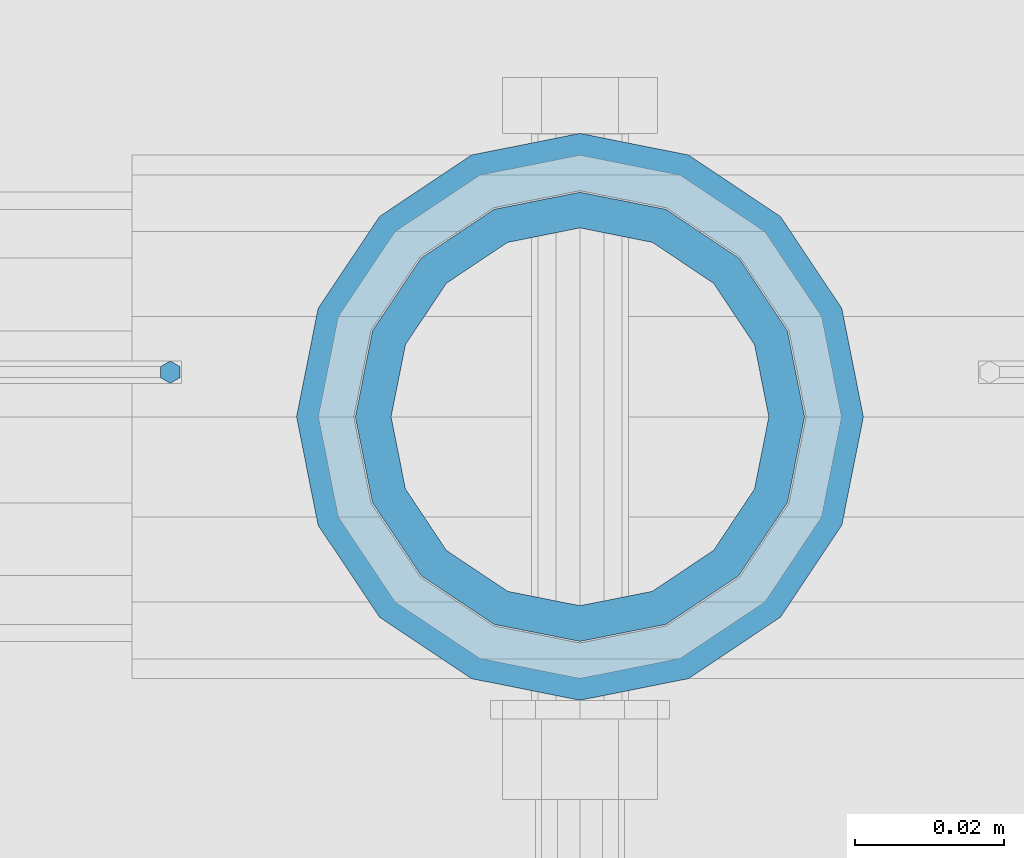
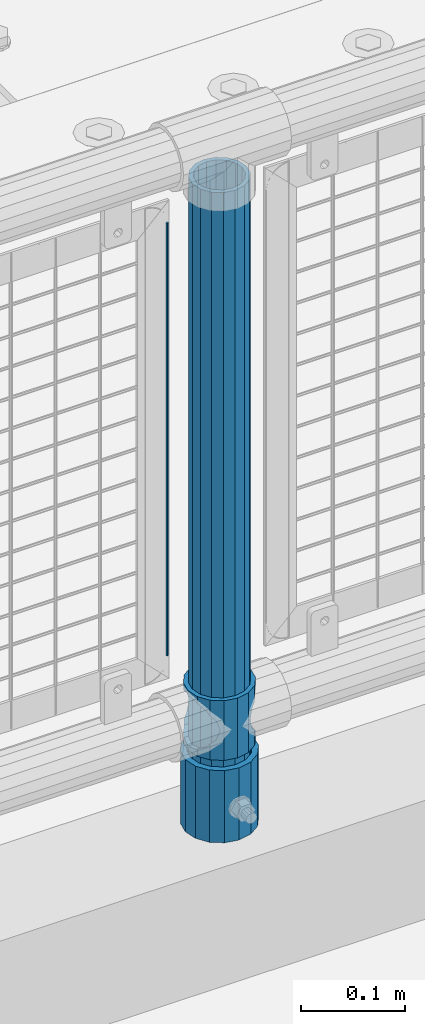
# One storey, part 78 of 257: 4 columns.
"""IFC2X3 building model written with IfcOpenShell, lengths in millimetres."""

from ifc_helpers import new_model, si_unit, frame, origin_with_axes, place, context, subcontext, project, spatial, faceted_brep, material, type_object, element, save


model = new_model("IFC2X3")

# Units and contexts
model_context = context("Model", 3, precision=1e-05, world=origin_with_axes())
body_context = subcontext(model_context, "Body", "Model", "MODEL_VIEW")
ifc_project = project(units=[si_unit("LENGTHUNIT", "METRE", prefix="MILLI"), si_unit("AREAUNIT", "SQUARE_METRE"), si_unit("VOLUMEUNIT", "CUBIC_METRE"), si_unit("MASSUNIT", "GRAM", prefix="KILO"), si_unit("TIMEUNIT", "SECOND"), si_unit("PLANEANGLEUNIT", "RADIAN"), si_unit("SOLIDANGLEUNIT", "STERADIAN"), si_unit("THERMODYNAMICTEMPERATUREUNIT", "DEGREE_CELSIUS"), si_unit("LUMINOUSINTENSITYUNIT", "LUMEN")], contexts=[model_context])

# Site, building, storey
site_placement = place(None, origin_with_axes())
site = spatial("IfcSite", under=ifc_project, at=site_placement, CompositionType="ELEMENT")
building_placement = place(site_placement, origin_with_axes())
building = spatial("IfcBuilding", under=site, at=building_placement, Name="Standard", CompositionType="ELEMENT")
storey_placement = place(building_placement, origin_with_axes())
storey = spatial("IfcBuildingStorey", under=building, at=storey_placement, Name="Undefined", CompositionType="ELEMENT", Elevation=0.0)

# Columns
ifc_material_1 = material()
column_type_1 = type_object("IfcColumnType", PredefinedType="NOTDEFINED")
column_1_placement = place(storey_placement, frame((49471.0, 10664.5, 168.02), z_axis=(0.0, 1.0, 0.0), x_axis=(0.0, 0.0, 1.0)))
element("IfcColumn", 1, at=column_1_placement, inside=storey, type_object=column_type_1, material=ifc_material_1, context=body_context, shape_type="Brep", body=[
    faceted_brep([(0.0, -31.75, 0.0), (0.0, -29.3331751572332, 12.1501989775916), (85.0, -29.3331751572332, 12.1501989775916), (85.0, -31.75, 0.0), (0.0, -22.4506403026753, 22.4506403026735), (85.0, -22.4506403026753, 22.4506403026735), (0.0, -12.1501989775934, 29.3331751572332), (85.0, -12.1501989775934, 29.3331751572332), (0.0, 0.0, 31.75), (85.0, 0.0, 31.75), (0.0, 12.1501989775934, 29.3331751572332), (85.0, 12.1501989775934, 29.3331751572332), (0.0, 22.4506403026753, 22.4506403026735), (85.0, 22.4506403026753, 22.4506403026735), (0.0, 29.3331751572332, 12.1501989775916), (85.0, 29.3331751572332, 12.1501989775916), (0.0, 31.75, 0.0), (85.0, 31.75, 0.0), (0.0, 29.3331751572332, -12.1501989775916), (85.0, 29.3331751572332, -12.1501989775916), (0.0, 22.4506403026753, -22.4506403026735), (85.0, 22.4506403026753, -22.4506403026735), (0.0, 12.1501989775934, -29.3331751572332), (85.0, 12.1501989775934, -29.3331751572332), (0.0, 0.0, -31.75), (85.0, 0.0, -31.75), (0.0, -12.1501989775934, -29.3331751572332), (85.0, -12.1501989775934, -29.3331751572332), (0.0, -22.4506403026753, -22.4506403026735), (85.0, -22.4506403026753, -22.4506403026735), (0.0, -29.3331751572332, -12.1501989775916), (85.0, -29.3331751572332, -12.1501989775916), (0.0, -38.0500000000029, 0.0), (0.0, -35.1536162120537, -14.561104601491), (85.0, -35.1536162120537, -14.561104601491), (85.0, -38.0500000000029, 0.0), (0.0, -26.9054130241493, -26.9054130241475), (85.0, -26.9054130241493, -26.9054130241475), (0.0, -14.5611046014892, -35.1536162120537), (85.0, -14.5611046014892, -35.1536162120537), (0.0, 0.0, -38.0499999999993), (85.0, 0.0, -38.0499999999993), (0.0, 14.5611046014892, -35.1536162120537), (85.0, 14.5611046014892, -35.1536162120537), (0.0, 26.9054130241493, -26.9054130241475), (85.0, 26.9054130241493, -26.9054130241475), (0.0, 35.1536162120537, -14.561104601491), (85.0, 35.1536162120537, -14.561104601491), (0.0, 38.0500000000029, 0.0), (85.0, 38.0500000000029, 0.0), (0.0, 35.1536162120537, 14.561104601491), (85.0, 35.1536162120537, 14.561104601491), (0.0, 26.9054130241493, 26.9054130241475), (85.0, 26.9054130241493, 26.9054130241475), (0.0, 14.5611046014892, 35.1536162120537), (85.0, 14.5611046014892, 35.1536162120537), (0.0, 0.0, 38.0499999999993), (85.0, 0.0, 38.0499999999993), (0.0, -14.5611046014892, 35.1536162120537), (85.0, -14.5611046014892, 35.1536162120537), (0.0, -26.9054130241493, 26.9054130241475), (85.0, -26.9054130241493, 26.9054130241475), (0.0, -35.1536162120537, 14.561104601491), (85.0, -35.1536162120537, 14.561104601491)], [[[0, 1, 2, 3]], [[1, 4, 5, 2]], [[4, 6, 7, 5]], [[6, 8, 9, 7]], [[8, 10, 11, 9]], [[10, 12, 13, 11]], [[12, 14, 15, 13]], [[14, 16, 17, 15]], [[16, 18, 19, 17]], [[18, 20, 21, 19]], [[20, 22, 23, 21]], [[22, 24, 25, 23]], [[24, 26, 27, 25]], [[26, 28, 29, 27]], [[28, 30, 31, 29]], [[30, 0, 3, 31]], [[32, 33, 34, 35]], [[33, 36, 37, 34]], [[36, 38, 39, 37]], [[38, 40, 41, 39]], [[40, 42, 43, 41]], [[42, 44, 45, 43]], [[44, 46, 47, 45]], [[46, 48, 49, 47]], [[48, 50, 51, 49]], [[50, 52, 53, 51]], [[52, 54, 55, 53]], [[54, 56, 57, 55]], [[56, 58, 59, 57]], [[58, 60, 61, 59]], [[60, 62, 63, 61]], [[62, 32, 35, 63]], [[37, 39, 41, 43, 45, 47, 49, 51, 53, 55, 57, 59, 61, 63, 35, 34], [5, 7, 9, 11, 13, 15, 17, 19, 21, 23, 25, 27, 29, 31, 3, 2]], [[62, 60, 58, 56, 54, 52, 50, 48, 46, 44, 42, 40, 38, 36, 33, 32], [30, 28, 26, 24, 22, 20, 18, 16, 14, 12, 10, 8, 6, 4, 1, 0]]]),
])
ifc_material_2 = material(Name="Misc_Undefined")
column_type_2 = type_object("IfcColumnType", PredefinedType="NOTDEFINED")
column_2_placement = place(storey_placement, frame((49471.0, 10664.5, 263.02), z_axis=(-1.0, 0.0, 0.0), x_axis=(0.0, 0.0, 1.0)))
element("IfcColumn", 2, at=column_2_placement, inside=storey, type_object=column_type_2, material=ifc_material_2, context=body_context, shape_type="Brep", body=[
    faceted_brep([(63.1897438117172, 11.6144421722802, -32.8397438117245), (63.1897438117172, 11.6144421722802, -28.0397438117143), (56.6106908090114, 21.4606908090118, -21.4606908090136), (56.6106908090114, 21.4606908090118, -27.1226768591077), (61.9623795176756, 13.4513226476338, -32.4743655677739), (46.7644421722801, 28.0397438117179, -11.6144421722784), (46.7644421722801, 28.0397438117179, -20.0882031229921), (51.5310424080039, 24.8548033587067, -24.8548033587067), (35.1500000000015, 30.35, 0.0), (35.1499999999996, 30.3500000000004, -16.6306603983758), (23.5355578277192, 28.0397438117179, -11.6144421722784), (23.5355578277192, 28.0397438117179, -20.0882031229921), (18.7689575919954, 24.8548033587067, -24.8548033587067), (13.6893091909879, 21.4606908090118, -21.4606908090136), (13.6893091909879, 21.4606908090118, -27.1226768591077), (8.3376204823237, 13.4513226476338, -32.4743655677739), (7.11025618828211, 11.6144421722802, -28.0397438117143), (7.11025618828211, 11.6144421722802, -32.8397438117245), (4.79999999999961, 0.0, -30.3499999999985), (4.79999999999961, 0.0, -35.1500000000015), (7.11025618828205, -11.6144421722802, -28.0397438117143), (7.11025618828205, -11.6144421722802, -32.8397438117245), (13.6893091909879, -21.4606908090118, -21.4606908090136), (13.6893091909879, -21.4606908090118, -27.1226768591077), (8.33762048232484, -13.4513226476338, -32.4743655677739), (23.5355578277191, -28.0397438117179, -11.6144421722784), (23.5355578277191, -28.0397438117179, -20.0882031229849), (18.7689575919987, -24.8548033587067, -24.8548033587067), (35.1500000000015, -30.35, 0.0), (35.1499999999996, -30.3500000000004, -16.6306603983685), (46.7644421722801, -28.0397438117179, -11.6144421722784), (46.7644421722801, -28.0397438117179, -20.0882031229849), (51.5310424080038, -24.8548033587067, -24.8548033587067), (56.6106908090114, -21.4606908090118, -21.4606908090136), (56.6106908090114, -21.4606908090118, -27.1226768591077), (61.9623795176756, -13.4513226476338, -32.4743655677739), (63.1897438117172, -11.6144421722802, -28.0397438117143), (63.1897438117172, -11.6144421722802, -32.8397438117245), (65.4999999999997, 0.0, -30.3499999999985), (65.4999999999997, 0.0, -35.1500000000015), (0.0, -28.0397438117179, -11.6144421722784), (0.0, -30.3500000000004, 0.0), (0.0, -21.4606908090118, -21.4606908090136), (0.0, -11.6144421722802, -28.0397438117143), (0.0, 0.0, -30.3499999999985), (0.0, 11.6144421722802, -28.0397438117143), (0.0, 21.4606908090118, -21.4606908090136), (0.0, 28.0397438117179, -11.6144421722784), (0.0, 30.3500000000004, 0.0), (0.0, 28.0397438117179, 11.6144421722784), (23.5355578277192, 28.0397438117179, 11.6144421722784), (0.0, 21.4606908090118, 21.4606908090136), (13.6893091909879, 21.4606908090118, 21.4606908090136), (0.0, 11.6144421722802, 28.0397438117143), (7.11025618828211, 11.6144421722802, 28.0397438117143), (0.0, 0.0, 30.3499999999985), (4.79999999999961, 0.0, 30.3499999999985), (0.0, -11.6144421722802, 28.0397438117143), (7.11025618828205, -11.6144421722802, 28.0397438117143), (0.0, -21.4606908090118, 21.4606908090136), (13.6893091909879, -21.4606908090118, 21.4606908090136), (0.0, -28.0397438117179, 11.6144421722784), (23.5355578277191, -28.0397438117179, 11.6144421722784), (0.0, -32.4743655677721, 13.4513226476338), (0.0, -35.1499999999996, 0.0), (70.2999999999993, -35.1499999999996, 0.0), (70.2999999999993, -32.4743655677721, 13.4513226476338), (0.0, 13.4513226476338, -32.4743655677739), (0.0, 24.8548033587067, -24.8548033587067), (0.0, 0.0, -35.1499999999996), (0.0, -13.4513226476338, -32.4743655677739), (0.0, -24.8548033587067, -24.8548033587067), (0.0, -24.8548033587067, 24.8548033587067), (0.0, -13.4513226476338, 32.4743655677739), (0.0, 0.0, 35.1499999999996), (0.0, 13.4513226476338, 32.4743655677739), (0.0, 24.8548033587067, 24.8548033587067), (0.0, 32.4743655677721, 13.4513226476338), (0.0, 35.1499999999996, 0.0), (0.0, 32.4743655677721, -13.4513226476338), (0.0, -32.4743655677721, -13.4513226476338), (70.2999999999993, 32.4743655677721, 13.4513226476338), (70.2999999999993, 35.1499999999996, 0.0), (70.2999999999993, 32.4743655677721, -13.4513226476338), (70.2999999999993, 24.8548033587067, -24.8548033587067), (70.2999999999993, 13.4513226476338, -32.4743655677739), (70.2999999999993, 0.0, -35.1500000000015), (70.2999999999993, -13.4513226476338, -32.4743655677739), (70.2999999999993, -24.8548033587067, -24.8548033587067), (70.2999999999993, -32.4743655677721, -13.4513226476338), (70.2999999999993, 28.0397438117179, 11.6144421722784), (70.2999999999993, 21.4606908090118, 21.4606908090136), (56.6106908090114, 21.4606908090118, 21.4606908090136), (46.7644421722801, 28.0397438117179, 11.6144421722784), (70.2999999999993, 11.6144421722802, 28.0397438117143), (63.1897438117172, 11.6144421722802, 28.0397438117143), (70.2999999999993, 0.0, 30.3499999999985), (65.4999999999997, 0.0, 30.3499999999985), (70.2999999999993, -11.6144421722802, 28.0397438117143), (63.1897438117172, -11.6144421722802, 28.0397438117143), (70.2999999999993, -21.4606908090118, 21.4606908090136), (56.6106908090114, -21.4606908090118, 21.4606908090136), (70.2999999999993, -28.0397438117179, 11.6144421722784), (46.7644421722801, -28.0397438117179, 11.6144421722784), (70.2999999999993, -11.6144421722802, -28.0397438117143), (70.2999999999993, 0.0, -30.3499999999985), (70.2999999999993, -21.4606908090118, -21.4606908090136), (70.2999999999993, -28.0397438117179, -11.6144421722784), (70.2999999999993, -30.3500000000004, 0.0), (70.2999999999993, 24.8548033587067, 24.8548033587067), (70.2999999999993, 13.4513226476338, 32.4743655677739), (70.2999999999993, 0.0, 35.1500000000015), (70.2999999999993, -13.4513226476338, 32.4743655677739), (70.2999999999993, -24.8548033587067, 24.8548033587067), (70.2999999999993, 30.3500000000004, 0.0), (70.2999999999993, 28.0397438117179, -11.6144421722784), (70.2999999999993, 21.4606908090118, -21.4606908090136), (70.2999999999993, 11.6144421722802, -28.0397438117143), (61.9623795176756, 13.4513226476338, 32.4743655677739), (51.5310424080039, 24.8548033587067, 24.8548033587067), (56.6106908090114, 21.4606908090118, 27.1226768591077), (65.4999999999997, 0.0, 35.1500000000015), (63.1897438117172, 11.6144421722802, 32.8397438117172), (63.1897438117172, -11.6144421722802, 32.8397438117172), (61.9623795176756, -13.4513226476338, 32.4743655677739), (56.6106908090114, -21.4606908090118, 27.1226768591077), (51.5310424080071, -24.8548033587067, 24.8548033587067), (18.7689575919987, -24.8548033587067, 24.8548033587067), (46.7644421722801, -28.0397438117179, 20.0882031229703), (35.1499999999996, -30.3500000000004, 16.6306603983539), (23.5355578277191, -28.0397438117179, 20.0882031229703), (8.3376204823237, -13.4513226476338, 32.4743655677739), (13.6893091909879, -21.4606908090118, 27.1226768591077), (4.79999999999961, 0.0, 35.1500000000015), (7.11025618828205, -11.6144421722802, 32.8397438117172), (7.11025618828211, 11.6144421722802, 32.8397438117172), (8.3376204823237, 13.4513226476338, 32.4743655677739), (13.6893091909879, 21.4606908090118, 27.1226768591077), (18.7689575919954, 24.8548033587067, 24.8548033587067), (23.5355578277192, 28.0397438117179, 20.0882031229849), (35.1499999999996, 30.3500000000004, 16.6306603983685), (46.7644421722801, 28.0397438117179, 20.0882031229849)], [[[0, 1, 2, 3, 4]], [[3, 2, 5, 6, 7]], [[6, 5, 8, 9]], [[9, 8, 10, 11]], [[12, 11, 10, 13, 14]], [[15, 14, 13, 16, 17]], [[17, 16, 18, 19]], [[19, 18, 20, 21]], [[21, 20, 22, 23, 24]], [[23, 22, 25, 26, 27]], [[26, 25, 28, 29]], [[29, 28, 30, 31]], [[32, 31, 30, 33, 34]], [[35, 34, 33, 36, 37]], [[37, 36, 38, 39]], [[39, 38, 1, 0]], [[40, 41, 28, 25]], [[42, 40, 25, 22]], [[43, 42, 22, 20]], [[44, 43, 20, 18]], [[45, 44, 18, 16]], [[46, 45, 16, 13]], [[47, 46, 13, 10]], [[48, 47, 10, 8]], [[49, 48, 8, 50]], [[51, 49, 50, 52]], [[53, 51, 52, 54]], [[55, 53, 54, 56]], [[57, 55, 56, 58]], [[59, 57, 58, 60]], [[61, 59, 60, 62]], [[41, 61, 62, 28]], [[63, 64, 65, 66]], [[67, 68, 12, 14, 15]], [[69, 67, 15, 17, 19]], [[24, 70, 69, 19, 21]], [[27, 71, 70, 24, 23]], [[63, 72, 73, 74, 75, 76, 77, 78, 79, 68, 67, 69, 70, 71, 80, 64], [40, 42, 43, 44, 45, 46, 47, 48, 49, 51, 53, 55, 57, 59, 61, 41]], [[78, 77, 81, 82]], [[79, 78, 82, 83]], [[9, 11, 12, 68, 79, 83, 84, 7, 6]], [[7, 84, 85, 4, 3]], [[4, 85, 86, 39, 0]], [[87, 88, 32, 34, 35]], [[86, 87, 35, 37, 39]], [[88, 89, 80, 71, 27, 26, 29, 31, 32]], [[64, 80, 89, 65]], [[90, 91, 92, 93]], [[91, 94, 95, 92]], [[94, 96, 97, 95]], [[96, 98, 99, 97]], [[98, 100, 101, 99]], [[100, 102, 103, 101]], [[104, 105, 38, 36]], [[106, 104, 36, 33]], [[107, 106, 33, 30]], [[108, 107, 30, 28]], [[102, 108, 28, 103]], [[88, 87, 86, 85, 84, 83, 82, 81, 109, 110, 111, 112, 113, 66, 65, 89], [100, 98, 96, 94, 91, 90, 114, 115, 116, 117, 105, 104, 106, 107, 108, 102]], [[118, 110, 109, 119, 120]], [[121, 111, 110, 118, 122]], [[112, 111, 121, 123, 124]], [[113, 112, 124, 125, 126]], [[127, 72, 63, 66, 113, 126, 128, 129, 130]], [[131, 73, 72, 127, 132]], [[133, 74, 73, 131, 134]], [[75, 74, 133, 135, 136]], [[76, 75, 136, 137, 138]], [[119, 109, 81, 77, 76, 138, 139, 140, 141]], [[92, 120, 119, 141, 93]], [[95, 122, 118, 120, 92]], [[97, 121, 122, 95]], [[99, 123, 121, 97]], [[101, 125, 124, 123, 99]], [[103, 128, 126, 125, 101]], [[28, 129, 128, 103]], [[62, 130, 129, 28]], [[60, 132, 127, 130, 62]], [[58, 134, 131, 132, 60]], [[56, 133, 134, 58]], [[54, 135, 133, 56]], [[52, 137, 136, 135, 54]], [[50, 139, 138, 137, 52]], [[8, 140, 139, 50]], [[93, 141, 140, 8]], [[114, 90, 93, 8]], [[115, 114, 8, 5]], [[116, 115, 5, 2]], [[117, 116, 2, 1]], [[105, 117, 1, 38]]]),
])
column_type_3 = type_object("IfcColumnType", PredefinedType="NOTDEFINED")
column_3_placement = place(storey_placement, frame((49471.0, 10664.5, 168.02), z_axis=(-1.0, 0.0, 0.0), x_axis=(0.0, 0.0, 1.0)))
element("IfcColumn", 3, at=column_3_placement, inside=storey, type_object=column_type_3, material=ifc_material_1, context=body_context, shape_type="Brep", body=[
    faceted_brep([(0.0, -25.3500000000004, 0.0), (0.0, -23.4203461491616, 9.70102501045767), (760.0, -23.4203461491616, 9.70102501045767), (760.0, -25.3500000000004, 0.0), (0.0, -17.9251569030785, 17.9251569030821), (760.0, -17.9251569030785, 17.9251569030821), (0.0, -9.70102501045585, 23.4203461491634), (760.0, -9.70102501045585, 23.4203461491634), (0.0, 0.0, 25.3499999999985), (760.0, 0.0, 25.3499999999985), (0.0, 9.70102501045585, 23.4203461491634), (760.0, 9.70102501045585, 23.4203461491634), (0.0, 17.9251569030785, 17.9251569030821), (760.0, 17.9251569030785, 17.9251569030821), (0.0, 23.4203461491616, 9.70102501045767), (760.0, 23.4203461491616, 9.70102501045767), (0.0, 25.3500000000004, 0.0), (760.0, 25.3500000000004, 0.0), (0.0, 23.4203461491616, -9.70102501045767), (760.0, 23.4203461491616, -9.70102501045767), (0.0, 17.9251569030785, -17.9251569030821), (760.0, 17.9251569030785, -17.9251569030821), (0.0, 9.70102501045585, -23.4203461491634), (760.0, 9.70102501045585, -23.4203461491634), (0.0, 0.0, -25.3499999999985), (760.0, 0.0, -25.3499999999985), (0.0, -9.70102501045585, -23.4203461491634), (760.0, -9.70102501045585, -23.4203461491634), (0.0, -17.9251569030785, -17.9251569030821), (760.0, -17.9251569030785, -17.9251569030821), (0.0, -23.4203461491616, -9.70102501045767), (760.0, -23.4203461491616, -9.70102501045767), (0.0, -30.1499999999996, 0.0), (0.0, -27.8549679052157, -11.5379054858058), (760.0, -27.8549679052157, -11.5379054858058), (760.0, -30.1499999999996, 0.0), (0.0, -21.3192694527752, -21.3192694527752), (760.0, -21.3192694527752, -21.3192694527752), (0.0, -11.5379054858076, -27.8549679052157), (760.0, -11.5379054858076, -27.8549679052157), (0.0, 0.0, -30.1500000000015), (760.0, 0.0, -30.1500000000015), (0.0, 11.5379054858076, -27.8549679052157), (760.0, 11.5379054858076, -27.8549679052157), (0.0, 21.3192694527752, -21.3192694527752), (760.0, 21.3192694527752, -21.3192694527752), (0.0, 27.8549679052157, -11.5379054858058), (760.0, 27.8549679052157, -11.5379054858058), (0.0, 30.1499999999996, 0.0), (760.0, 30.1499999999996, 0.0), (0.0, 27.8549679052157, 11.5379054858058), (760.0, 27.8549679052157, 11.5379054858058), (0.0, 21.3192694527752, 21.3192694527752), (760.0, 21.3192694527752, 21.3192694527752), (0.0, 11.5379054858076, 27.8549679052157), (760.0, 11.5379054858076, 27.8549679052157), (0.0, 0.0, 30.1500000000015), (760.0, 0.0, 30.1500000000015), (0.0, -11.5379054858076, 27.8549679052157), (760.0, -11.5379054858076, 27.8549679052157), (0.0, -21.3192694527752, 21.3192694527752), (760.0, -21.3192694527752, 21.3192694527752), (0.0, -27.8549679052157, 11.5379054858058), (760.0, -27.8549679052157, 11.5379054858058)], [[[0, 1, 2, 3]], [[1, 4, 5, 2]], [[4, 6, 7, 5]], [[6, 8, 9, 7]], [[8, 10, 11, 9]], [[10, 12, 13, 11]], [[12, 14, 15, 13]], [[14, 16, 17, 15]], [[16, 18, 19, 17]], [[18, 20, 21, 19]], [[20, 22, 23, 21]], [[22, 24, 25, 23]], [[24, 26, 27, 25]], [[26, 28, 29, 27]], [[28, 30, 31, 29]], [[30, 0, 3, 31]], [[32, 33, 34, 35]], [[33, 36, 37, 34]], [[36, 38, 39, 37]], [[38, 40, 41, 39]], [[40, 42, 43, 41]], [[42, 44, 45, 43]], [[44, 46, 47, 45]], [[46, 48, 49, 47]], [[48, 50, 51, 49]], [[50, 52, 53, 51]], [[52, 54, 55, 53]], [[54, 56, 57, 55]], [[56, 58, 59, 57]], [[58, 60, 61, 59]], [[60, 62, 63, 61]], [[62, 32, 35, 63]], [[37, 39, 41, 43, 45, 47, 49, 51, 53, 55, 57, 59, 61, 63, 35, 34], [5, 7, 9, 11, 13, 15, 17, 19, 21, 23, 25, 27, 29, 31, 3, 2]], [[62, 60, 58, 56, 54, 52, 50, 48, 46, 44, 42, 40, 38, 36, 33, 32], [30, 28, 26, 24, 22, 20, 18, 16, 14, 12, 10, 8, 6, 4, 1, 0]]]),
])
column_type_4 = type_object("IfcColumnType", Name="D3", PredefinedType="NOTDEFINED")
column_4_placement = place(storey_placement, frame((49416.0, 10670.5, 378.020000000001), z_axis=(-1.0, 0.0, 0.0), x_axis=(0.0, 0.0, 1.0)))
element("IfcColumn", 4, at=column_4_placement, inside=storey, type_object=column_type_4, material=ifc_material_2, ObjectType="D3", context=body_context, shape_type="Brep", body=[
    faceted_brep([(0.0, -1.5, -5.6843418860808e-14), (0.0, -0.750000000001819, -1.29903810567669), (510.0, -0.75, -1.29903810567339), (510.0, -1.5, 0.0), (7.27595761418343e-12, 0.749999999998181, -1.29903810567669), (510.0, 0.75, -1.29903810567339), (0.0, 1.5, -5.6843418860808e-14), (510.0, 1.5, 0.0), (7.27595761418343e-12, 0.749999999998181, 1.29903810567669), (510.0, 0.75, 1.29903810567339), (0.0, -0.750000000001819, 1.29903810567669), (510.0, -0.75, 1.29903810567339)], [[[0, 1, 2, 3]], [[1, 4, 5, 2]], [[4, 6, 7, 5]], [[6, 8, 9, 7]], [[8, 10, 11, 9]], [[10, 0, 3, 11]], [[5, 7, 9, 11, 3, 2]], [[10, 8, 6, 4, 1, 0]]]),
])

save(model, "model.ifc")
